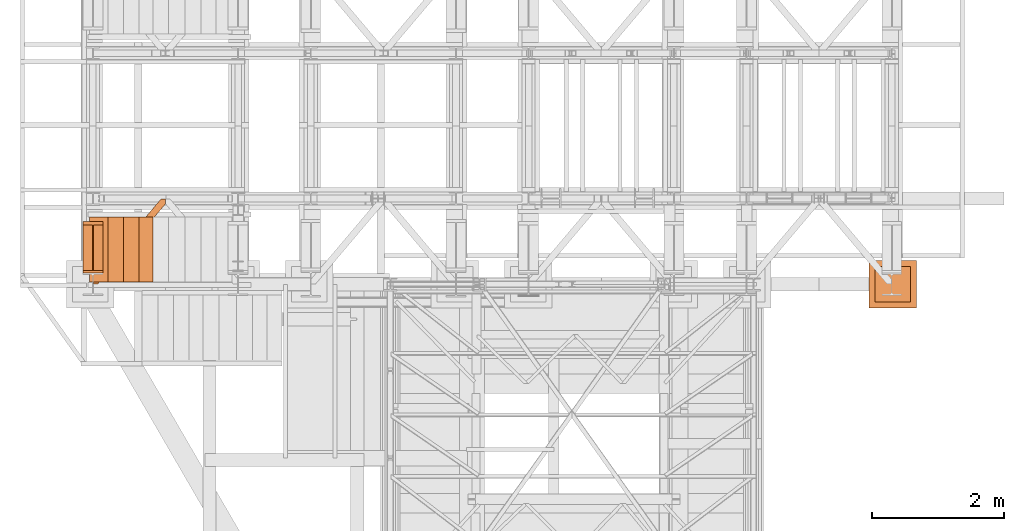
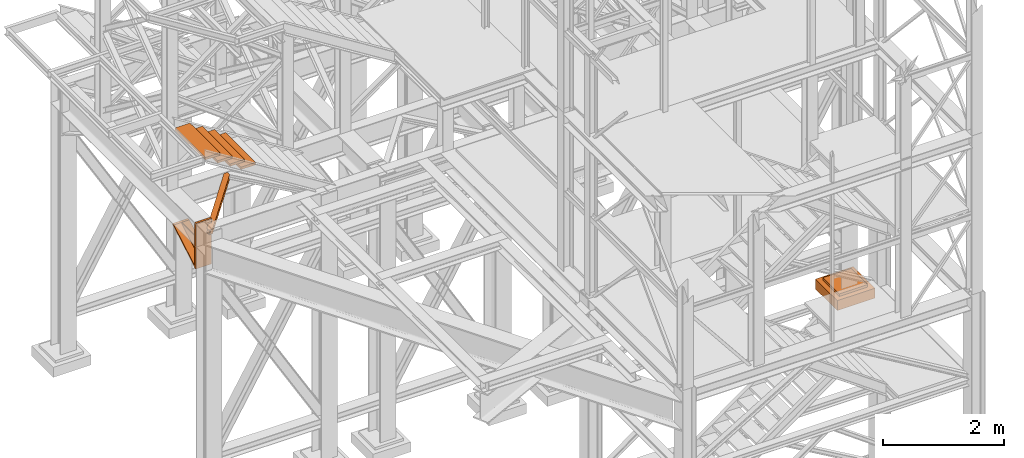
# One storey, part 82 of 208: 7 proxies.
"""IFC2X3 building model written with IfcOpenShell, lengths in millimetres."""

from ifc_helpers import new_model, entity, si_unit, converted_unit, frame, origin, origin_with_axes, place, context, subcontext, project, spatial, faceted_brep, element, save


model = new_model("IFC2X3")

# Units and contexts
model_context = context("Model", 3, precision=1e-05, world=origin())
plan_context = context("Plan", 3, precision=1e-05, world=origin())
body_context = subcontext(model_context, "Body", "Model", "MODEL_VIEW")
ifc_project = project(units=[si_unit("LENGTHUNIT", "METRE", prefix="MILLI"), converted_unit("PLANEANGLEUNIT", "DEGREE", entity("IfcPlaneAngleMeasure", 0.0174532925199433), si_unit("PLANEANGLEUNIT", "RADIAN"), dimensions=[0, 0, 0, 0, 0, 0, 0]), si_unit("AREAUNIT", "SQUARE_METRE"), si_unit("VOLUMEUNIT", "CUBIC_METRE")], contexts=[model_context, plan_context])

# Building, storey
building_placement = place(None, origin())
building = spatial("IfcBuilding", under=ifc_project, at=building_placement, CompositionType="COMPLEX")
storey_placement = place(building_placement, origin_with_axes())
storey = spatial("IfcBuildingStorey", under=building, at=storey_placement, Name="Geschoss", CompositionType="ELEMENT")

# Proxies
proxy_1_placement = place(storey_placement, frame((-3456.745037431798, -17092.57439173937, 4367.230005364415), z_axis=(0.0, 0.0, 1.0), x_axis=(1.0, 0.0, 0.0)))
element("IfcBuildingElementProxy", 1, at=proxy_1_placement, inside=storey, context=body_context, shape_type="Brep", body=[
    faceted_brep([(0.01000000000021828, 40.0099999999984, 18.61000000000058), (300.0100000000002, 40.0099999999984, 18.61000000000058), (300.0100000000002, 779.8719999999994, 445.7700000000004), (0.01000000000021828, 779.8719999999994, 445.7700000000004), (0.01000000000021828, 779.8719999999994, 445.7700000000004), (300.0100000000002, 779.8719999999994, 445.7700000000004), (300.0100000000002, 729.8159999999989, 445.7710000000006), (157.5100000000002, 729.8159999999989, 445.7710000000006), (157.5100000000002, 40.0099999999984, 445.7700000000004), (142.5100000000002, 40.0099999999984, 445.7700000000004), (142.5100000000002, 729.8159999999989, 445.7710000000006), (0.01000000000021828, 729.8159999999989, 445.7710000000006), (0.01000000000021828, 729.8159999999989, 445.7710000000006), (142.5100000000002, 729.8159999999989, 445.7710000000006), (142.5100000000002, 40.0099999999984, 47.51000000000022), (0.01000000000021828, 40.0099999999984, 47.51000000000022), (157.5100000000002, 40.0099999999984, 47.51000000000022), (157.5100000000002, 729.8159999999989, 445.7710000000006), (300.0100000000002, 729.8159999999989, 445.7710000000006), (300.0100000000002, 40.0099999999984, 47.51000000000022), (0.01000000000021828, 40.0099999999984, 18.61000000000058), (0.01000000000021828, 779.8719999999994, 445.7700000000004), (0.01000000000021828, 729.8159999999989, 445.7710000000006), (0.01000000000021828, 40.0099999999984, 47.51000000000022), (0.01000000000021828, 40.0099999999984, 917.7700000000004), (0.01000000000021828, 0.00999999999839929, 917.7700000000004), (0.01000000000021828, 0.00999999999839929, 0.01000000000021828), (0.01000000000021828, 40.0099999999984, 0.01000000000021828), (300.0100000000002, 0.00999999999839929, 917.7700000000004), (300.0100000000002, 40.0099999999984, 917.7700000000004), (300.0100000000002, 40.0099999999984, 47.51000000000022), (300.0100000000002, 729.8159999999989, 445.7710000000006), (300.0100000000002, 779.8719999999994, 445.7700000000004), (300.0100000000002, 40.0099999999984, 18.61000000000058), (300.0100000000002, 40.0099999999984, 0.01000000000021828), (300.0100000000002, 0.00999999999839929, 0.01000000000021828), (300.0100000000002, 0.00999999999839929, 917.7700000000004), (0.01000000000021828, 0.00999999999839929, 917.7700000000004), (0.01000000000021828, 40.0099999999984, 917.7700000000004), (300.0100000000002, 40.0099999999984, 917.7700000000004), (300.0100000000002, 40.0099999999984, 917.7700000000004), (0.01000000000021828, 40.0099999999984, 917.7700000000004), (0.01000000000021828, 40.0099999999984, 47.51000000000022), (142.5100000000002, 40.0099999999984, 47.51000000000022), (142.5100000000002, 40.0099999999984, 445.7700000000004), (157.5100000000002, 40.0099999999984, 445.7700000000004), (157.5100000000002, 40.0099999999984, 47.51000000000022), (300.0100000000002, 40.0099999999984, 47.51000000000022), (300.0100000000002, 40.0099999999984, 18.61000000000058), (0.01000000000021828, 40.0099999999984, 18.61000000000058), (0.01000000000021828, 40.0099999999984, 0.01000000000021828), (300.0100000000002, 40.0099999999984, 0.01000000000021828), (300.0100000000002, 40.0099999999984, 0.01000000000021828), (0.01000000000021828, 40.0099999999984, 0.01000000000021828), (0.01000000000021828, 0.00999999999839929, 0.01000000000021828), (300.0100000000002, 0.00999999999839929, 0.01000000000021828), (300.0100000000002, 0.00999999999839929, 0.01000000000021828), (0.01000000000021828, 0.00999999999839929, 0.01000000000021828), (0.01000000000021828, 0.00999999999839929, 917.7700000000004), (300.0100000000002, 0.00999999999839929, 917.7700000000004), (142.5100000000002, 40.0099999999984, 47.51000000000022), (142.5100000000002, 729.8159999999989, 445.7710000000006), (142.5100000000002, 40.0099999999984, 445.7700000000004), (157.5100000000002, 40.0099999999984, 47.51000000000022), (157.5100000000002, 40.0099999999984, 445.7700000000004), (157.5100000000002, 729.8159999999989, 445.7710000000006)], [[[0, 1, 2, 3]], [[4, 5, 6, 7, 8, 9, 10, 11]], [[12, 13, 14, 15]], [[16, 17, 18, 19]], [[20, 21, 22, 23, 24, 25, 26, 27]], [[28, 29, 30, 31, 32, 33, 34, 35]], [[36, 37, 38, 39]], [[40, 41, 42, 43, 44, 45, 46, 47]], [[48, 49, 50, 51]], [[52, 53, 54, 55]], [[56, 57, 58, 59]], [[60, 61, 62]], [[63, 64, 65]]], orient=[[False], [False], [False], [False], [False], [False], [False], [False], [False], [False], [False], [False], [False]]),
])
proxy_2_placement = place(storey_placement, frame((-3300.745031419179, -17257.87439359531, 5101.990016164881), z_axis=(0.0, 0.0, 1.0), x_axis=(1.0, 0.0, 0.0)))
element("IfcBuildingElementProxy", 2, at=proxy_2_placement, inside=storey, context=body_context, shape_type="Brep", body=[
    faceted_brep([(1028.512359102908, 1290.610003345228, 8.010001311302403), (0.01000000000021828, 75.10721531451782, 8.010001311303313), (0.01000000000021828, 75.10721531451782, 0.01000000000021828), (1028.512359102908, 1290.610003345228, 0.01000000000021828), (1028.512359102908, 1290.610003345228, 0.01000000000021828), (0.01000000000021828, 75.10721531451782, 0.01000000000021828), (0.01000000000021828, 0.00999999999839929, 0.01000000000021828), (67.46148411605282, 0.00999999999839929, 0.01000000000021828), (1094.009999947844, 1213.203700528482, 0.01000000000021828), (1094.009999947844, 1290.610003345228, 0.01000000000021828), (1094.009999947844, 1213.203700528482, 0.01000000000021828), (67.46148411605282, 0.00999999999839929, 0.01000000000021828), (67.46148411605282, 0.00999999999839929, 8.010001311302403), (1094.009999947846, 1213.203700528482, 8.010001311302403), (1094.009999947846, 1213.203700528482, 8.010001311302403), (67.46148411605282, 0.00999999999839929, 8.010001311302403), (20.95815950654287, 0.00999999999839929, 8.010001311302403), (1094.009999947844, 1268.162175066993, 8.010001311302403), (1094.009999947844, 1268.162175066993, 8.010001311302403), (20.95815950654287, 0.00999999999839929, 8.010001311302403), (12.82264470841801, 0.00999999999839929, 9.253033826351384), (1094.009999947844, 1277.776874373869, 9.253033826351384), (1094.009999947844, 1277.776874373869, 9.253033826351384), (12.82264470841801, 0.00999999999839929, 9.253033826351384), (6.86703880668756, 0.00999999999839929, 13.79946006298087), (1094.009999947844, 1284.815317712277, 13.79946006298087), (1094.009999947844, 1284.815317712277, 13.79946006298087), (6.86703880668756, 0.00999999999839929, 13.79946006298087), (5.23872549636144, 0.00999999999839929, 20.01000141560962), (1094.009999947844, 1286.739687988118, 20.01000141561053), (1094.009999947844, 1286.739687988118, 20.01000141561053), (5.23872549636144, 0.00999999999839929, 20.01000141560962), (5.23872549636144, 0.00999999999839929, 76.01000128150008), (1094.009999947844, 1286.739687988116, 76.01000128150008), (1094.009999947844, 1286.739687988116, 76.01000128150008), (5.23872549636144, 0.00999999999839929, 76.01000128150008), (6.86703880668756, 0.00999999999839929, 82.2205407714846), (1094.009999947844, 1284.815317712277, 82.2205407714846), (1094.009999947844, 1284.815317712277, 82.2205407714846), (6.86703880668756, 0.00999999999839929, 82.2205407714846), (12.82264470841801, 0.00999999999839929, 86.76696700811317), (1094.009999947844, 1277.776874373869, 86.76696700811408), (1094.009999947844, 1277.776874373869, 86.76696700811408), (12.82264470841801, 0.00999999999839929, 86.76696700811317), (20.95815950654469, 0.00999999999839929, 88.00999952316306), (1094.009999947844, 1268.162175066993, 88.00999952316306), (1094.009999947844, 1268.162175066993, 88.00999952316306), (20.95815950654469, 0.00999999999839929, 88.00999952316306), (67.46148411605282, 0.00999999999839929, 88.00999952316397), (1094.009999947844, 1213.203700528482, 88.00999952316306), (1094.009999947844, 1213.203700528482, 88.00999952316306), (67.46148411605282, 0.00999999999839929, 88.00999952316397), (67.46148411605282, 0.00999999999839929, 96.01000083446525), (1094.009999947846, 1213.203700528484, 96.01000083446525), (1094.009999947846, 1213.203700528484, 96.01000083446525), (67.46148411605282, 0.00999999999839929, 96.01000083446525), (0.01000000000021828, 0.00999999999839929, 96.01000083446525), (0.01000000000021828, 75.10721531451782, 96.01000083446525), (1028.51235910291, 1290.610003345228, 96.01000083446525), (1094.009999947846, 1290.610003345228, 96.01000083446525), (1028.51235910291, 1290.610003345228, 96.01000083446525), (0.01000000000021828, 75.10721531451782, 96.01000083446525), (0.01000000000021828, 75.10721531451782, 88.00999952316306), (1028.51235910291, 1290.610003345228, 88.00999952316306), (1028.51235910291, 1290.610003345228, 88.00999952316306), (0.01000000000021828, 75.10721531451782, 88.00999952316306), (0.01000000000021828, 20.14874077600325, 88.00999952316215), (1075.01568371242, 1290.610003345228, 88.00999952316306), (1075.01568371242, 1290.610003345228, 88.00999952316306), (0.01000000000021828, 20.14874077600325, 88.00999952316215), (0.01000000000021828, 10.53404146912726, 86.76696700811499), (1083.151198510544, 1290.610003345228, 86.76696700811408), (1083.151198510544, 1290.610003345228, 86.76696700811408), (0.01000000000021828, 10.53404146912726, 86.76696700811499), (0.01000000000021828, 3.495598130721191, 82.2205407714855), (1089.106804412275, 1290.610003345228, 82.2205407714846), (1089.106804412275, 1290.610003345228, 82.2205407714846), (0.01000000000021828, 3.495598130721191, 82.2205407714855), (0.01000000000021828, 1.571227854878089, 76.01000128150008), (1090.735117722603, 1290.610003345228, 76.01000128150008), (1090.735117722603, 1290.610003345228, 76.01000128150008), (0.01000000000021828, 1.571227854878089, 76.01000128150008), (0.01000000000021828, 1.571227854878089, 20.01000141561053), (1090.735117722601, 1290.610003345228, 20.01000141561053), (1090.735117722601, 1290.610003345228, 20.01000141561053), (0.01000000000021828, 1.571227854878089, 20.01000141561053), (0.01000000000021828, 3.495598130721191, 13.79946006298087), (1089.106804412275, 1290.610003345228, 13.79946006298087), (1089.106804412275, 1290.610003345228, 13.79946006298087), (0.01000000000021828, 3.495598130721191, 13.79946006298087), (0.01000000000021828, 10.53404146912726, 9.253033826351384), (1083.151198510544, 1290.610003345228, 9.253033826351384), (1083.151198510544, 1290.610003345228, 9.253033826351384), (0.01000000000021828, 10.53404146912726, 9.253033826351384), (0.01000000000021828, 20.14874077600325, 8.010001311302403), (1075.015683712418, 1290.610003345228, 8.010001311302403), (1075.015683712418, 1290.610003345228, 8.010001311302403), (0.01000000000021828, 20.14874077600325, 8.010001311302403), (0.01000000000021828, 75.10721531451782, 8.010001311303313), (1028.512359102908, 1290.610003345228, 8.010001311302403), (1094.009999947844, 1213.203700528482, 0.01000000000021828), (1094.009999947846, 1213.203700528482, 8.010001311302403), (1094.009999947844, 1268.162175066993, 8.010001311302403), (1094.009999947844, 1277.776874373869, 9.253033826351384), (1094.009999947844, 1284.815317712277, 13.79946006298087), (1094.009999947844, 1286.739687988118, 20.01000141561053), (1094.009999947844, 1286.739687988116, 76.01000128150008), (1094.009999947844, 1284.815317712277, 82.2205407714846), (1094.009999947844, 1277.776874373869, 86.76696700811408), (1094.009999947844, 1268.162175066993, 88.00999952316306), (1094.009999947844, 1213.203700528482, 88.00999952316306), (1094.009999947846, 1213.203700528484, 96.01000083446525), (1094.009999947846, 1290.610003345228, 96.01000083446525), (1094.009999947844, 1290.610003345228, 0.01000000000021828), (1094.009999947846, 1290.610003345228, 96.01000083446525), (1028.51235910291, 1290.610003345228, 96.01000083446525), (1028.51235910291, 1290.610003345228, 88.00999952316306), (1075.01568371242, 1290.610003345228, 88.00999952316306), (1083.151198510544, 1290.610003345228, 86.76696700811408), (1089.106804412275, 1290.610003345228, 82.2205407714846), (1090.735117722603, 1290.610003345228, 76.01000128150008), (1090.735117722601, 1290.610003345228, 20.01000141561053), (1089.106804412275, 1290.610003345228, 13.79946006298087), (1083.151198510544, 1290.610003345228, 9.253033826351384), (1075.015683712418, 1290.610003345228, 8.010001311302403), (1028.512359102908, 1290.610003345228, 8.010001311302403), (1028.512359102908, 1290.610003345228, 0.01000000000021828), (1094.009999947844, 1290.610003345228, 0.01000000000021828), (0.01000000000021828, 75.10721531451782, 0.01000000000021828), (0.01000000000021828, 75.10721531451782, 8.010001311303313), (0.01000000000021828, 20.14874077600325, 8.010001311302403), (0.01000000000021828, 10.53404146912726, 9.253033826351384), (0.01000000000021828, 3.495598130721191, 13.79946006298087), (0.01000000000021828, 1.571227854878089, 20.01000141561053), (0.01000000000021828, 1.571227854878089, 76.01000128150008), (0.01000000000021828, 3.495598130721191, 82.2205407714855), (0.01000000000021828, 10.53404146912726, 86.76696700811499), (0.01000000000021828, 20.14874077600325, 88.00999952316215), (0.01000000000021828, 75.10721531451782, 88.00999952316306), (0.01000000000021828, 75.10721531451782, 96.01000083446525), (0.01000000000021828, 0.00999999999839929, 96.01000083446525), (0.01000000000021828, 0.00999999999839929, 0.01000000000021828), (67.46148411605282, 0.00999999999839929, 0.01000000000021828), (0.01000000000021828, 0.00999999999839929, 0.01000000000021828), (0.01000000000021828, 0.00999999999839929, 96.01000083446525), (67.46148411605282, 0.00999999999839929, 96.01000083446525), (67.46148411605282, 0.00999999999839929, 88.00999952316397), (20.95815950654469, 0.00999999999839929, 88.00999952316306), (12.82264470841801, 0.00999999999839929, 86.76696700811317), (6.86703880668756, 0.00999999999839929, 82.2205407714846), (5.23872549636144, 0.00999999999839929, 76.01000128150008), (5.23872549636144, 0.00999999999839929, 20.01000141560962), (6.86703880668756, 0.00999999999839929, 13.79946006298087), (12.82264470841801, 0.00999999999839929, 9.253033826351384), (20.95815950654287, 0.00999999999839929, 8.010001311302403), (67.46148411605282, 0.00999999999839929, 8.010001311302403)], [[[0, 1, 2, 3]], [[4, 5, 6, 7, 8, 9]], [[10, 11, 12, 13]], [[14, 15, 16, 17]], [[18, 19, 20, 21]], [[22, 23, 24, 25]], [[26, 27, 28, 29]], [[30, 31, 32, 33]], [[34, 35, 36, 37]], [[38, 39, 40, 41]], [[42, 43, 44, 45]], [[46, 47, 48, 49]], [[50, 51, 52, 53]], [[54, 55, 56, 57, 58, 59]], [[60, 61, 62, 63]], [[64, 65, 66, 67]], [[68, 69, 70, 71]], [[72, 73, 74, 75]], [[76, 77, 78, 79]], [[80, 81, 82, 83]], [[84, 85, 86, 87]], [[88, 89, 90, 91]], [[92, 93, 94, 95]], [[96, 97, 98, 99]], [[100, 101, 102, 103, 104, 105, 106, 107, 108, 109, 110, 111, 112, 113]], [[114, 115, 116, 117, 118, 119, 120, 121, 122, 123, 124, 125, 126, 127]], [[128, 129, 130, 131, 132, 133, 134, 135, 136, 137, 138, 139, 140, 141]], [[142, 143, 144, 145, 146, 147, 148, 149, 150, 151, 152, 153, 154, 155]]], orient=[[False], [False], [False], [False], [False], [False], [False], [False], [False], [False], [False], [False], [False], [False], [False], [False], [False], [False], [False], [False], [False], [False], [False], [False], [False], [False], [False], [False]]),
])
proxy_3_placement = place(storey_placement, frame((8449.779705904713, -17622.57439531565, -315.0099999999999), z_axis=(0.0, 0.0, 1.0), x_axis=(1.0, 0.0, 0.0)))
element("IfcBuildingElementProxy", 3, at=proxy_3_placement, inside=storey, context=body_context, shape_type="Brep", body=[
    faceted_brep([(630.0100000000002, 630.0099999999984, 250.01), (630.0100000000002, 90.0099999999984, 250.01), (90.01000000000022, 90.0099999999984, 250.01), (90.01000000000022, 630.0099999999984, 250.01), (630.0100000000002, 630.0099999999984, 200.01), (630.0100000000002, 90.0099999999984, 200.01), (630.0100000000002, 90.0099999999984, 250.01), (630.0100000000002, 630.0099999999984, 250.01), (90.01000000000022, 630.0099999999984, 200.01), (630.0100000000002, 630.0099999999984, 200.01), (630.0100000000002, 630.0099999999984, 250.01), (90.01000000000022, 630.0099999999984, 250.01), (90.01000000000022, 90.0099999999984, 200.01), (90.01000000000022, 630.0099999999984, 200.01), (90.01000000000022, 630.0099999999984, 250.01), (90.01000000000022, 90.0099999999984, 250.01), (630.0100000000002, 90.0099999999984, 200.01), (90.01000000000022, 90.0099999999984, 200.01), (90.01000000000022, 90.0099999999984, 250.01), (630.0100000000002, 90.0099999999984, 250.01), (720.0100000000002, 0.00999999999839929, 0.009999999999990905), (720.0100000000002, 720.0099999999984, 0.009999999999990905), (0.01000000000021828, 720.0099999999984, 0.009999999999990905), (0.01000000000021828, 0.00999999999839929, 0.009999999999990905), (720.0100000000002, 720.0099999999984, 200.01), (720.0100000000002, 0.00999999999839929, 200.01), (0.01000000000021828, 0.00999999999839929, 200.01), (0.01000000000021828, 720.0099999999984, 200.01), (90.01000000000022, 90.0099999999984, 200.01), (630.0100000000002, 90.0099999999984, 200.01), (630.0100000000002, 630.0099999999984, 200.01), (90.01000000000022, 630.0099999999984, 200.01), (720.0100000000002, 720.0099999999984, 0.009999999999990905), (720.0100000000002, 0.00999999999839929, 0.009999999999990905), (720.0100000000002, 0.00999999999839929, 200.01), (720.0100000000002, 720.0099999999984, 200.01), (0.01000000000021828, 720.0099999999984, 0.009999999999990905), (720.0100000000002, 720.0099999999984, 0.009999999999990905), (720.0100000000002, 720.0099999999984, 200.01), (0.01000000000021828, 720.0099999999984, 200.01), (0.01000000000021828, 0.00999999999839929, 0.009999999999990905), (0.01000000000021828, 720.0099999999984, 0.009999999999990905), (0.01000000000021828, 720.0099999999984, 200.01), (0.01000000000021828, 0.00999999999839929, 200.01), (720.0100000000002, 0.00999999999839929, 0.009999999999990905), (0.01000000000021828, 0.00999999999839929, 0.009999999999990905), (0.01000000000021828, 0.00999999999839929, 200.01), (720.0100000000002, 0.00999999999839929, 200.01)], [[[0, 1, 2, 3]], [[4, 5, 6, 7]], [[8, 9, 10, 11]], [[12, 13, 14, 15]], [[16, 17, 18, 19]], [[20, 21, 22, 23]], [[24, 25, 26, 27], [28, 29, 30, 31]], [[32, 33, 34, 35]], [[36, 37, 38, 39]], [[40, 41, 42, 43]], [[44, 45, 46, 47]]], orient=[[False], [False], [False], [False], [False], [False], [False, False], [False], [False], [False], [False]]),
])
for number, where, z_axis, x_axis in (
    (4, (-2676.526415575506, -17228.55346893691, 6179.621503199068), (0.0, 0.0, 1.0), (1.0, 0.0, 0.0)),
    (5, (-2889.02327878041, -17228.55346893691, 6316.648265018103), (0.0, 0.0, 1.0), (1.0, 0.0, 0.0)),
    (6, (-3123.287934412027, -17228.55346893691, 6463.70404147361), (0.0, 0.0, 1.0), (1.0, 0.0, 0.0)),
    (7, (-3357.552590043645, -17228.55346893691, 6610.759817929117), (0.0, 0.0, 1.0), (1.0, 0.0, 0.0)),
):
    element("IfcBuildingElementProxy", number, at=place(storey_placement, frame(where, z_axis=z_axis, x_axis=x_axis)), inside=storey, context=body_context, shape_type="Brep", body=[
        faceted_brep([(0.01000000000021828, 0.00999999999839929, 0.01000000000021828), (280.2746556316179, 0.00999999999839929, 0.01000000000021828), (280.2746556316179, 988.9080206708568, 0.01000000000021828), (0.01000000000021828, 988.9080206708568, 0.01000000000021828), (280.2746556316179, 0.00999999999839929, 50.01000000000022), (0.01000000000021828, 0.00999999999839929, 50.01000000000022), (0.01000000000021828, 988.9080206708568, 50.01000000000022), (280.2746556316179, 988.9080206708568, 50.01000000000022), (280.2746556316179, 0.00999999999839929, 0.01000000000021828), (0.01000000000021828, 0.00999999999839929, 0.01000000000021828), (0.01000000000021828, 0.00999999999839929, 50.01000000000022), (280.2746556316179, 0.00999999999839929, 50.01000000000022), (280.2746556316179, 988.9080206708568, 0.01000000000021828), (280.2746556316179, 0.00999999999839929, 0.01000000000021828), (280.2746556316179, 0.00999999999839929, 50.01000000000022), (280.2746556316179, 988.9080206708568, 50.01000000000022), (0.01000000000021828, 988.9080206708568, 0.01000000000021828), (280.2746556316179, 988.9080206708568, 0.01000000000021828), (280.2746556316179, 988.9080206708568, 50.01000000000022), (0.01000000000021828, 988.9080206708568, 50.01000000000022), (0.01000000000021828, 0.00999999999839929, 0.01000000000021828), (0.01000000000021828, 988.9080206708568, 0.01000000000021828), (0.01000000000021828, 988.9080206708568, 50.01000000000022), (0.01000000000021828, 0.00999999999839929, 50.01000000000022)], [[[0, 1, 2, 3]], [[4, 5, 6, 7]], [[8, 9, 10, 11]], [[12, 13, 14, 15]], [[16, 17, 18, 19]], [[20, 21, 22, 23]]], orient=[[False], [False], [False], [False], [False], [False]]),
    ])

save(model, "model.ifc")
